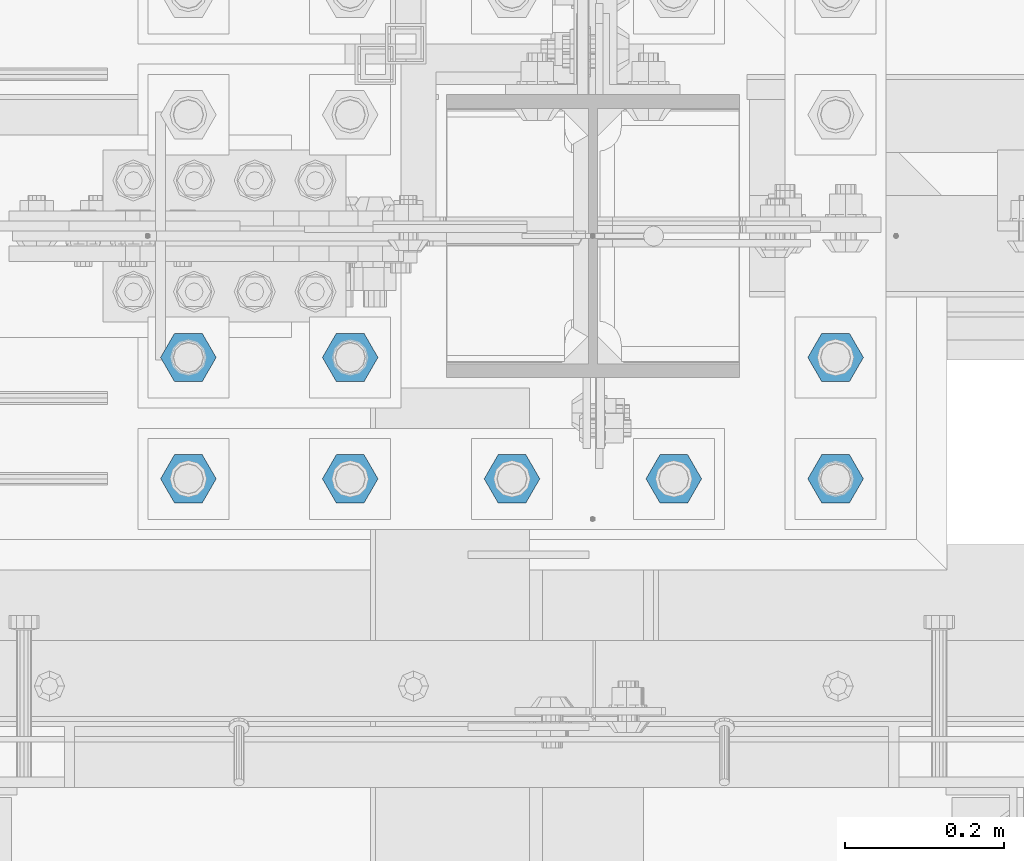
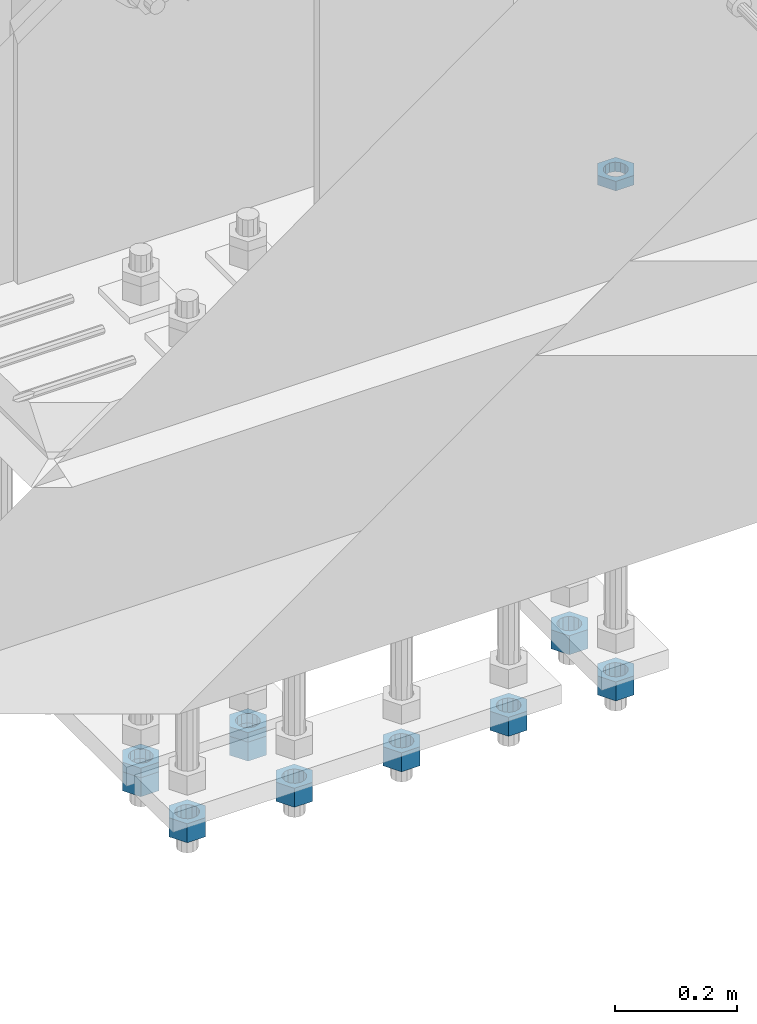
# One storey, part 2815 of 3843: 11 beams, 1 element without a shape of its own.
"""IFC2X3 building model written with IfcOpenShell, lengths in millimetres."""

from ifc_helpers import new_model, si_unit, frame, origin_with_axes, place, context, subcontext, project, spatial, faceted_brep, material, type_object, element, aggregate, save


model = new_model("IFC2X3")

# Units and contexts
model_context = context("Model", 3, precision=1e-05, world=origin_with_axes())
body_context = subcontext(model_context, "Body", "Model", "MODEL_VIEW")
ifc_project = project(units=[si_unit("LENGTHUNIT", "METRE", prefix="MILLI"), si_unit("AREAUNIT", "SQUARE_METRE"), si_unit("VOLUMEUNIT", "CUBIC_METRE"), si_unit("MASSUNIT", "GRAM", prefix="KILO"), si_unit("TIMEUNIT", "SECOND"), si_unit("PLANEANGLEUNIT", "RADIAN"), si_unit("SOLIDANGLEUNIT", "STERADIAN"), si_unit("THERMODYNAMICTEMPERATUREUNIT", "DEGREE_CELSIUS"), si_unit("LUMINOUSINTENSITYUNIT", "LUMEN")], contexts=[model_context])

# Site, building, storey
site_placement = place(None, origin_with_axes())
site = spatial("IfcSite", under=ifc_project, at=site_placement, CompositionType="ELEMENT")
building_placement = place(site_placement, origin_with_axes())
building = spatial("IfcBuilding", under=site, at=building_placement, Name="Undefined", CompositionType="ELEMENT")
storey_placement = place(building_placement, origin_with_axes())
storey = spatial("IfcBuildingStorey", under=building, at=storey_placement, Name="Undefined", CompositionType="ELEMENT", Elevation=0.0)

# Assembly, beams
assembly_placement = place(storey_placement, origin_with_axes())
assembly = element("IfcElementAssembly", 1, at=assembly_placement, inside=storey, Name="TEMPLATE", AssemblyPlace="NOTDEFINED", PredefinedType="RIGID_FRAME")
ifc_material = material(Name="STEEL/A572-50")
beam_type_1 = type_object("IfcBeamType", Name="1-1/2_HEAVY_HEX_NUT", PredefinedType="NOTDEFINED")
beam_1_placement = place(assembly_placement, frame((49301.4, 25311.1, 28746.4500015259), z_axis=(0.0, -1.0, 0.0), x_axis=(0.0, 0.0, -1.0)))
beam_1 = element("IfcBeam", 2, at=beam_1_placement, type_object=beam_type_1, material=ifc_material, Name="NUT", ObjectType="1-1/2_HEAVY_HEX_NUT", context=body_context, shape_type="Brep", body=[
    faceted_brep([(0.0, -34.9199981689453, 0.0), (0.0, -17.4599990844727, -30.25), (38.0999999999985, -17.4599990844727, -30.25), (38.0999999999985, -34.9199981689453, 0.0), (0.0, 17.4599990844727, -30.25), (38.0999999999985, 17.4599990844727, -30.25), (0.0, 34.9199981689453, 0.0), (38.0999999999985, 34.9199981689453, 0.0), (0.0, 17.4599990844727, 30.25), (38.0999999999985, 17.4599990844727, 30.25), (0.0, -17.4599990844727, 30.25), (38.0999999999985, -17.4599990844727, 30.25), (0.0, 0.0, 20.6399993896484), (0.0, 8.9553601105581, 18.5959968835959), (38.0999999999985, 8.9553601105581, 18.5959968835959), (38.0999999999985, 0.0, 20.6399993896484), (0.0, 16.1370013209525, 12.8688291298167), (38.0999999999985, 16.1370013209525, 12.8688291298167), (0.0, 20.1225115123816, 4.59283194104501), (38.0999999999985, 20.1225115123816, 4.59283194104501), (0.0, 20.1225115123816, -4.59283194104501), (38.0999999999985, 20.1225115123816, -4.59283194104501), (0.0, 16.1370013209525, -12.8688291298167), (38.0999999999985, 16.1370013209525, -12.8688291298167), (0.0, 8.9553601105581, -18.5959968835959), (38.0999999999985, 8.9553601105581, -18.5959968835959), (0.0, 0.0, -20.6399993896484), (38.0999999999985, 0.0, -20.6399993896484), (0.0, -8.9553601105581, -18.5959968835959), (38.0999999999985, -8.9553601105581, -18.5959968835959), (0.0, -16.1370013209525, -12.8688291298167), (38.0999999999985, -16.1370013209525, -12.8688291298167), (0.0, -20.1225115123816, -4.59283194104501), (38.0999999999985, -20.1225115123816, -4.59283194104501), (0.0, -20.1225115123816, 4.59283194104501), (38.0999999999985, -20.1225115123816, 4.59283194104501), (0.0, -16.1370013209525, 12.8688291298167), (38.0999999999985, -16.1370013209525, 12.8688291298167), (0.0, -8.9553601105581, 18.5959968835959), (38.0999999999985, -8.9553601105581, 18.5959968835959)], [[[0, 1, 2, 3]], [[1, 4, 5, 2]], [[4, 6, 7, 5]], [[6, 8, 9, 7]], [[8, 10, 11, 9]], [[10, 0, 3, 11]], [[12, 13, 14, 15]], [[13, 16, 17, 14]], [[16, 18, 19, 17]], [[18, 20, 21, 19]], [[20, 22, 23, 21]], [[22, 24, 25, 23]], [[24, 26, 27, 25]], [[26, 28, 29, 27]], [[28, 30, 31, 29]], [[30, 32, 33, 31]], [[32, 34, 35, 33]], [[34, 36, 37, 35]], [[36, 38, 39, 37]], [[38, 12, 15, 39]], [[5, 7, 9, 11, 3, 2], [17, 19, 21, 23, 25, 27, 29, 31, 33, 35, 37, 39, 15, 14]], [[10, 8, 6, 4, 1, 0], [38, 36, 34, 32, 30, 28, 26, 24, 22, 20, 18, 16, 13, 12]]]),
])
beam_2_placement = place(assembly_placement, frame((49098.2, 25311.1, 28746.4500015259), z_axis=(0.0, -1.0, 0.0), x_axis=(0.0, 0.0, -1.0)))
beam_2 = element("IfcBeam", 3, at=beam_2_placement, type_object=beam_type_1, material=ifc_material, Name="NUT", ObjectType="1-1/2_HEAVY_HEX_NUT", context=body_context, shape_type="Brep", body=[
    faceted_brep([(0.0, -34.9199981689453, 0.0), (0.0, -17.4599990844727, -30.25), (38.0999999999985, -17.4599990844727, -30.25), (38.0999999999985, -34.9199981689453, 0.0), (0.0, 17.4599990844727, -30.25), (38.0999999999985, 17.4599990844727, -30.25), (0.0, 34.9199981689453, 0.0), (38.0999999999985, 34.9199981689453, 0.0), (0.0, 17.4599990844727, 30.25), (38.0999999999985, 17.4599990844727, 30.25), (0.0, -17.4599990844727, 30.25), (38.0999999999985, -17.4599990844727, 30.25), (0.0, 0.0, 20.6399993896484), (0.0, 8.9553601105581, 18.5959968835959), (38.0999999999985, 8.9553601105581, 18.5959968835959), (38.0999999999985, 0.0, 20.6399993896484), (0.0, 16.1370013209525, 12.8688291298167), (38.0999999999985, 16.1370013209525, 12.8688291298167), (0.0, 20.1225115123816, 4.59283194104501), (38.0999999999985, 20.1225115123816, 4.59283194104501), (0.0, 20.1225115123816, -4.59283194104501), (38.0999999999985, 20.1225115123816, -4.59283194104501), (0.0, 16.1370013209525, -12.8688291298167), (38.0999999999985, 16.1370013209525, -12.8688291298167), (0.0, 8.9553601105581, -18.5959968835959), (38.0999999999985, 8.9553601105581, -18.5959968835959), (0.0, 0.0, -20.6399993896484), (38.0999999999985, 0.0, -20.6399993896484), (0.0, -8.9553601105581, -18.5959968835959), (38.0999999999985, -8.9553601105581, -18.5959968835959), (0.0, -16.1370013209525, -12.8688291298167), (38.0999999999985, -16.1370013209525, -12.8688291298167), (0.0, -20.1225115123816, -4.59283194104501), (38.0999999999985, -20.1225115123816, -4.59283194104501), (0.0, -20.1225115123816, 4.59283194104501), (38.0999999999985, -20.1225115123816, 4.59283194104501), (0.0, -16.1370013209525, 12.8688291298167), (38.0999999999985, -16.1370013209525, 12.8688291298167), (0.0, -8.9553601105581, 18.5959968835959), (38.0999999999985, -8.9553601105581, 18.5959968835959)], [[[0, 1, 2, 3]], [[1, 4, 5, 2]], [[4, 6, 7, 5]], [[6, 8, 9, 7]], [[8, 10, 11, 9]], [[10, 0, 3, 11]], [[12, 13, 14, 15]], [[13, 16, 17, 14]], [[16, 18, 19, 17]], [[18, 20, 21, 19]], [[20, 22, 23, 21]], [[22, 24, 25, 23]], [[24, 26, 27, 25]], [[26, 28, 29, 27]], [[28, 30, 31, 29]], [[30, 32, 33, 31]], [[32, 34, 35, 33]], [[34, 36, 37, 35]], [[36, 38, 39, 37]], [[38, 12, 15, 39]], [[5, 7, 9, 11, 3, 2], [17, 19, 21, 23, 25, 27, 29, 31, 33, 35, 37, 39, 15, 14]], [[10, 8, 6, 4, 1, 0], [38, 36, 34, 32, 30, 28, 26, 24, 22, 20, 18, 16, 13, 12]]]),
])
beam_3_placement = place(assembly_placement, frame((48895.0, 25311.1, 28746.4500015259), z_axis=(0.0, -1.0, 0.0), x_axis=(0.0, 0.0, -1.0)))
beam_3 = element("IfcBeam", 4, at=beam_3_placement, type_object=beam_type_1, material=ifc_material, Name="NUT", ObjectType="1-1/2_HEAVY_HEX_NUT", context=body_context, shape_type="Brep", body=[
    faceted_brep([(0.0, -34.9199981689453, 0.0), (0.0, -17.4599990844727, -30.25), (38.0999999999985, -17.4599990844727, -30.25), (38.0999999999985, -34.9199981689453, 0.0), (0.0, 17.4599990844727, -30.25), (38.0999999999985, 17.4599990844727, -30.25), (0.0, 34.9199981689453, 0.0), (38.0999999999985, 34.9199981689453, 0.0), (0.0, 17.4599990844727, 30.25), (38.0999999999985, 17.4599990844727, 30.25), (0.0, -17.4599990844727, 30.25), (38.0999999999985, -17.4599990844727, 30.25), (0.0, 0.0, 20.6399993896484), (0.0, 8.9553601105581, 18.5959968835959), (38.0999999999985, 8.9553601105581, 18.5959968835959), (38.0999999999985, 0.0, 20.6399993896484), (0.0, 16.1370013209525, 12.8688291298167), (38.0999999999985, 16.1370013209525, 12.8688291298167), (0.0, 20.1225115123816, 4.59283194104501), (38.0999999999985, 20.1225115123816, 4.59283194104501), (0.0, 20.1225115123816, -4.59283194104501), (38.0999999999985, 20.1225115123816, -4.59283194104501), (0.0, 16.1370013209525, -12.8688291298167), (38.0999999999985, 16.1370013209525, -12.8688291298167), (0.0, 8.9553601105581, -18.5959968835959), (38.0999999999985, 8.9553601105581, -18.5959968835959), (0.0, 0.0, -20.6399993896484), (38.0999999999985, 0.0, -20.6399993896484), (0.0, -8.9553601105581, -18.5959968835959), (38.0999999999985, -8.9553601105581, -18.5959968835959), (0.0, -16.1370013209525, -12.8688291298167), (38.0999999999985, -16.1370013209525, -12.8688291298167), (0.0, -20.1225115123816, -4.59283194104501), (38.0999999999985, -20.1225115123816, -4.59283194104501), (0.0, -20.1225115123816, 4.59283194104501), (38.0999999999985, -20.1225115123816, 4.59283194104501), (0.0, -16.1370013209525, 12.8688291298167), (38.0999999999985, -16.1370013209525, 12.8688291298167), (0.0, -8.9553601105581, 18.5959968835959), (38.0999999999985, -8.9553601105581, 18.5959968835959)], [[[0, 1, 2, 3]], [[1, 4, 5, 2]], [[4, 6, 7, 5]], [[6, 8, 9, 7]], [[8, 10, 11, 9]], [[10, 0, 3, 11]], [[12, 13, 14, 15]], [[13, 16, 17, 14]], [[16, 18, 19, 17]], [[18, 20, 21, 19]], [[20, 22, 23, 21]], [[22, 24, 25, 23]], [[24, 26, 27, 25]], [[26, 28, 29, 27]], [[28, 30, 31, 29]], [[30, 32, 33, 31]], [[32, 34, 35, 33]], [[34, 36, 37, 35]], [[36, 38, 39, 37]], [[38, 12, 15, 39]], [[5, 7, 9, 11, 3, 2], [17, 19, 21, 23, 25, 27, 29, 31, 33, 35, 37, 39, 15, 14]], [[10, 8, 6, 4, 1, 0], [38, 36, 34, 32, 30, 28, 26, 24, 22, 20, 18, 16, 13, 12]]]),
])
beam_4_placement = place(assembly_placement, frame((48691.8, 25311.1, 28746.4500015259), z_axis=(0.0, 1.0, 0.0), x_axis=(0.0, 0.0, -1.0)))
beam_4 = element("IfcBeam", 5, at=beam_4_placement, type_object=beam_type_1, material=ifc_material, Name="NUT", ObjectType="1-1/2_HEAVY_HEX_NUT", context=body_context, shape_type="Brep", body=[
    faceted_brep([(0.0, -34.9199981689453, 0.0), (0.0, -17.4599990844727, -30.25), (38.0999999999985, -17.4599990844727, -30.25), (38.0999999999985, -34.9199981689453, 0.0), (0.0, 17.4599990844727, -30.25), (38.0999999999985, 17.4599990844727, -30.25), (0.0, 34.9199981689453, 0.0), (38.0999999999985, 34.9199981689453, 0.0), (0.0, 17.4599990844727, 30.25), (38.0999999999985, 17.4599990844727, 30.25), (0.0, -17.4599990844727, 30.25), (38.0999999999985, -17.4599990844727, 30.25), (0.0, 0.0, 20.6399993896484), (0.0, 8.9553601105581, 18.5959968835959), (38.0999999999985, 8.9553601105581, 18.5959968835959), (38.0999999999985, 0.0, 20.6399993896484), (0.0, 16.1370013209525, 12.8688291298167), (38.0999999999985, 16.1370013209525, 12.8688291298167), (0.0, 20.1225115123816, 4.59283194104501), (38.0999999999985, 20.1225115123816, 4.59283194104501), (0.0, 20.1225115123816, -4.59283194104501), (38.0999999999985, 20.1225115123816, -4.59283194104501), (0.0, 16.1370013209525, -12.8688291298167), (38.0999999999985, 16.1370013209525, -12.8688291298167), (0.0, 8.9553601105581, -18.5959968835959), (38.0999999999985, 8.9553601105581, -18.5959968835959), (0.0, 0.0, -20.6399993896484), (38.0999999999985, 0.0, -20.6399993896484), (0.0, -8.9553601105581, -18.5959968835959), (38.0999999999985, -8.9553601105581, -18.5959968835959), (0.0, -16.1370013209525, -12.8688291298167), (38.0999999999985, -16.1370013209525, -12.8688291298167), (0.0, -20.1225115123816, -4.59283194104501), (38.0999999999985, -20.1225115123816, -4.59283194104501), (0.0, -20.1225115123816, 4.59283194104501), (38.0999999999985, -20.1225115123816, 4.59283194104501), (0.0, -16.1370013209525, 12.8688291298167), (38.0999999999985, -16.1370013209525, 12.8688291298167), (0.0, -8.9553601105581, 18.5959968835959), (38.0999999999985, -8.9553601105581, 18.5959968835959)], [[[0, 1, 2, 3]], [[1, 4, 5, 2]], [[4, 6, 7, 5]], [[6, 8, 9, 7]], [[8, 10, 11, 9]], [[10, 0, 3, 11]], [[12, 13, 14, 15]], [[13, 16, 17, 14]], [[16, 18, 19, 17]], [[18, 20, 21, 19]], [[20, 22, 23, 21]], [[22, 24, 25, 23]], [[24, 26, 27, 25]], [[26, 28, 29, 27]], [[28, 30, 31, 29]], [[30, 32, 33, 31]], [[32, 34, 35, 33]], [[34, 36, 37, 35]], [[36, 38, 39, 37]], [[38, 12, 15, 39]], [[5, 7, 9, 11, 3, 2], [17, 19, 21, 23, 25, 27, 29, 31, 33, 35, 37, 39, 15, 14]], [[10, 8, 6, 4, 1, 0], [38, 36, 34, 32, 30, 28, 26, 24, 22, 20, 18, 16, 13, 12]]]),
])
beam_5_placement = place(assembly_placement, frame((48488.6, 25311.1, 28746.4500015259), z_axis=(0.0, 1.0, 0.0), x_axis=(0.0, 0.0, -1.0)))
beam_5 = element("IfcBeam", 6, at=beam_5_placement, type_object=beam_type_1, material=ifc_material, Name="NUT", ObjectType="1-1/2_HEAVY_HEX_NUT", context=body_context, shape_type="Brep", body=[
    faceted_brep([(0.0, -34.9199981689453, 0.0), (0.0, -17.4599990844727, -30.25), (38.0999999999985, -17.4599990844727, -30.25), (38.0999999999985, -34.9199981689453, 0.0), (0.0, 17.4599990844727, -30.25), (38.0999999999985, 17.4599990844727, -30.25), (0.0, 34.9199981689453, 0.0), (38.0999999999985, 34.9199981689453, 0.0), (0.0, 17.4599990844727, 30.25), (38.0999999999985, 17.4599990844727, 30.25), (0.0, -17.4599990844727, 30.25), (38.0999999999985, -17.4599990844727, 30.25), (0.0, 0.0, 20.6399993896484), (0.0, 8.9553601105581, 18.5959968835959), (38.0999999999985, 8.9553601105581, 18.5959968835959), (38.0999999999985, 0.0, 20.6399993896484), (0.0, 16.1370013209525, 12.8688291298167), (38.0999999999985, 16.1370013209525, 12.8688291298167), (0.0, 20.1225115123816, 4.59283194104501), (38.0999999999985, 20.1225115123816, 4.59283194104501), (0.0, 20.1225115123816, -4.59283194104501), (38.0999999999985, 20.1225115123816, -4.59283194104501), (0.0, 16.1370013209525, -12.8688291298167), (38.0999999999985, 16.1370013209525, -12.8688291298167), (0.0, 8.9553601105581, -18.5959968835959), (38.0999999999985, 8.9553601105581, -18.5959968835959), (0.0, 0.0, -20.6399993896484), (38.0999999999985, 0.0, -20.6399993896484), (0.0, -8.9553601105581, -18.5959968835959), (38.0999999999985, -8.9553601105581, -18.5959968835959), (0.0, -16.1370013209525, -12.8688291298167), (38.0999999999985, -16.1370013209525, -12.8688291298167), (0.0, -20.1225115123816, -4.59283194104501), (38.0999999999985, -20.1225115123816, -4.59283194104501), (0.0, -20.1225115123816, 4.59283194104501), (38.0999999999985, -20.1225115123816, 4.59283194104501), (0.0, -16.1370013209525, 12.8688291298167), (38.0999999999985, -16.1370013209525, 12.8688291298167), (0.0, -8.9553601105581, 18.5959968835959), (38.0999999999985, -8.9553601105581, 18.5959968835959)], [[[0, 1, 2, 3]], [[1, 4, 5, 2]], [[4, 6, 7, 5]], [[6, 8, 9, 7]], [[8, 10, 11, 9]], [[10, 0, 3, 11]], [[12, 13, 14, 15]], [[13, 16, 17, 14]], [[16, 18, 19, 17]], [[18, 20, 21, 19]], [[20, 22, 23, 21]], [[22, 24, 25, 23]], [[24, 26, 27, 25]], [[26, 28, 29, 27]], [[28, 30, 31, 29]], [[30, 32, 33, 31]], [[32, 34, 35, 33]], [[34, 36, 37, 35]], [[36, 38, 39, 37]], [[38, 12, 15, 39]], [[5, 7, 9, 11, 3, 2], [17, 19, 21, 23, 25, 27, 29, 31, 33, 35, 37, 39, 15, 14]], [[10, 8, 6, 4, 1, 0], [38, 36, 34, 32, 30, 28, 26, 24, 22, 20, 18, 16, 13, 12]]]),
])
beam_6_placement = place(assembly_placement, frame((49301.4, 25463.5, 28746.4500015259), z_axis=(0.0, -1.0, 0.0), x_axis=(0.0, 0.0, -1.0)))
beam_6 = element("IfcBeam", 7, at=beam_6_placement, type_object=beam_type_1, material=ifc_material, Name="NUT", ObjectType="1-1/2_HEAVY_HEX_NUT", context=body_context, shape_type="Brep", body=[
    faceted_brep([(0.0, -34.9199981689453, 0.0), (0.0, -17.4599990844727, -30.25), (38.0999999999985, -17.4599990844727, -30.25), (38.0999999999985, -34.9199981689453, 0.0), (0.0, 17.4599990844727, -30.25), (38.0999999999985, 17.4599990844727, -30.25), (0.0, 34.9199981689453, 0.0), (38.0999999999985, 34.9199981689453, 0.0), (0.0, 17.4599990844727, 30.25), (38.0999999999985, 17.4599990844727, 30.25), (0.0, -17.4599990844727, 30.25), (38.0999999999985, -17.4599990844727, 30.25), (0.0, 0.0, 20.6399993896484), (0.0, 8.9553601105581, 18.5959968835959), (38.0999999999985, 8.9553601105581, 18.5959968835959), (38.0999999999985, 0.0, 20.6399993896484), (0.0, 16.1370013209525, 12.8688291298167), (38.0999999999985, 16.1370013209525, 12.8688291298167), (0.0, 20.1225115123816, 4.59283194104501), (38.0999999999985, 20.1225115123816, 4.59283194104501), (0.0, 20.1225115123816, -4.59283194104501), (38.0999999999985, 20.1225115123816, -4.59283194104501), (0.0, 16.1370013209525, -12.8688291298167), (38.0999999999985, 16.1370013209525, -12.8688291298167), (0.0, 8.9553601105581, -18.5959968835959), (38.0999999999985, 8.9553601105581, -18.5959968835959), (0.0, 0.0, -20.6399993896484), (38.0999999999985, 0.0, -20.6399993896484), (0.0, -8.9553601105581, -18.5959968835959), (38.0999999999985, -8.9553601105581, -18.5959968835959), (0.0, -16.1370013209525, -12.8688291298167), (38.0999999999985, -16.1370013209525, -12.8688291298167), (0.0, -20.1225115123816, -4.59283194104501), (38.0999999999985, -20.1225115123816, -4.59283194104501), (0.0, -20.1225115123816, 4.59283194104501), (38.0999999999985, -20.1225115123816, 4.59283194104501), (0.0, -16.1370013209525, 12.8688291298167), (38.0999999999985, -16.1370013209525, 12.8688291298167), (0.0, -8.9553601105581, 18.5959968835959), (38.0999999999985, -8.9553601105581, 18.5959968835959)], [[[0, 1, 2, 3]], [[1, 4, 5, 2]], [[4, 6, 7, 5]], [[6, 8, 9, 7]], [[8, 10, 11, 9]], [[10, 0, 3, 11]], [[12, 13, 14, 15]], [[13, 16, 17, 14]], [[16, 18, 19, 17]], [[18, 20, 21, 19]], [[20, 22, 23, 21]], [[22, 24, 25, 23]], [[24, 26, 27, 25]], [[26, 28, 29, 27]], [[28, 30, 31, 29]], [[30, 32, 33, 31]], [[32, 34, 35, 33]], [[34, 36, 37, 35]], [[36, 38, 39, 37]], [[38, 12, 15, 39]], [[5, 7, 9, 11, 3, 2], [17, 19, 21, 23, 25, 27, 29, 31, 33, 35, 37, 39, 15, 14]], [[10, 8, 6, 4, 1, 0], [38, 36, 34, 32, 30, 28, 26, 24, 22, 20, 18, 16, 13, 12]]]),
])
beam_7_placement = place(assembly_placement, frame((48691.8, 25463.5, 28746.4500015259), z_axis=(0.0, 1.0, 0.0), x_axis=(0.0, 0.0, -1.0)))
beam_7 = element("IfcBeam", 8, at=beam_7_placement, type_object=beam_type_1, material=ifc_material, Name="NUT", ObjectType="1-1/2_HEAVY_HEX_NUT", context=body_context, shape_type="Brep", body=[
    faceted_brep([(0.0, -34.9199981689453, 0.0), (0.0, -17.4599990844727, -30.25), (38.0999999999985, -17.4599990844727, -30.25), (38.0999999999985, -34.9199981689453, 0.0), (0.0, 17.4599990844727, -30.25), (38.0999999999985, 17.4599990844727, -30.25), (0.0, 34.9199981689453, 0.0), (38.0999999999985, 34.9199981689453, 0.0), (0.0, 17.4599990844727, 30.25), (38.0999999999985, 17.4599990844727, 30.25), (0.0, -17.4599990844727, 30.25), (38.0999999999985, -17.4599990844727, 30.25), (0.0, 0.0, 20.6399993896484), (0.0, 8.9553601105581, 18.5959968835959), (38.0999999999985, 8.9553601105581, 18.5959968835959), (38.0999999999985, 0.0, 20.6399993896484), (0.0, 16.1370013209525, 12.8688291298167), (38.0999999999985, 16.1370013209525, 12.8688291298167), (0.0, 20.1225115123816, 4.59283194104501), (38.0999999999985, 20.1225115123816, 4.59283194104501), (0.0, 20.1225115123816, -4.59283194104501), (38.0999999999985, 20.1225115123816, -4.59283194104501), (0.0, 16.1370013209525, -12.8688291298167), (38.0999999999985, 16.1370013209525, -12.8688291298167), (0.0, 8.9553601105581, -18.5959968835959), (38.0999999999985, 8.9553601105581, -18.5959968835959), (0.0, 0.0, -20.6399993896484), (38.0999999999985, 0.0, -20.6399993896484), (0.0, -8.9553601105581, -18.5959968835959), (38.0999999999985, -8.9553601105581, -18.5959968835959), (0.0, -16.1370013209525, -12.8688291298167), (38.0999999999985, -16.1370013209525, -12.8688291298167), (0.0, -20.1225115123816, -4.59283194104501), (38.0999999999985, -20.1225115123816, -4.59283194104501), (0.0, -20.1225115123816, 4.59283194104501), (38.0999999999985, -20.1225115123816, 4.59283194104501), (0.0, -16.1370013209525, 12.8688291298167), (38.0999999999985, -16.1370013209525, 12.8688291298167), (0.0, -8.9553601105581, 18.5959968835959), (38.0999999999985, -8.9553601105581, 18.5959968835959)], [[[0, 1, 2, 3]], [[1, 4, 5, 2]], [[4, 6, 7, 5]], [[6, 8, 9, 7]], [[8, 10, 11, 9]], [[10, 0, 3, 11]], [[12, 13, 14, 15]], [[13, 16, 17, 14]], [[16, 18, 19, 17]], [[18, 20, 21, 19]], [[20, 22, 23, 21]], [[22, 24, 25, 23]], [[24, 26, 27, 25]], [[26, 28, 29, 27]], [[28, 30, 31, 29]], [[30, 32, 33, 31]], [[32, 34, 35, 33]], [[34, 36, 37, 35]], [[36, 38, 39, 37]], [[38, 12, 15, 39]], [[5, 7, 9, 11, 3, 2], [17, 19, 21, 23, 25, 27, 29, 31, 33, 35, 37, 39, 15, 14]], [[10, 8, 6, 4, 1, 0], [38, 36, 34, 32, 30, 28, 26, 24, 22, 20, 18, 16, 13, 12]]]),
])
beam_8_placement = place(assembly_placement, frame((48488.6, 25463.5, 28746.4500015259), z_axis=(0.0, 1.0, 0.0), x_axis=(0.0, 0.0, -1.0)))
beam_8 = element("IfcBeam", 9, at=beam_8_placement, type_object=beam_type_1, material=ifc_material, Name="NUT", ObjectType="1-1/2_HEAVY_HEX_NUT", context=body_context, shape_type="Brep", body=[
    faceted_brep([(0.0, -34.9199981689453, 0.0), (0.0, -17.4599990844727, -30.25), (38.0999999999985, -17.4599990844727, -30.25), (38.0999999999985, -34.9199981689453, 0.0), (0.0, 17.4599990844727, -30.25), (38.0999999999985, 17.4599990844727, -30.25), (0.0, 34.9199981689453, 0.0), (38.0999999999985, 34.9199981689453, 0.0), (0.0, 17.4599990844727, 30.25), (38.0999999999985, 17.4599990844727, 30.25), (0.0, -17.4599990844727, 30.25), (38.0999999999985, -17.4599990844727, 30.25), (0.0, 0.0, 20.6399993896484), (0.0, 8.9553601105581, 18.5959968835959), (38.0999999999985, 8.9553601105581, 18.5959968835959), (38.0999999999985, 0.0, 20.6399993896484), (0.0, 16.1370013209525, 12.8688291298167), (38.0999999999985, 16.1370013209525, 12.8688291298167), (0.0, 20.1225115123816, 4.59283194104501), (38.0999999999985, 20.1225115123816, 4.59283194104501), (0.0, 20.1225115123816, -4.59283194104501), (38.0999999999985, 20.1225115123816, -4.59283194104501), (0.0, 16.1370013209525, -12.8688291298167), (38.0999999999985, 16.1370013209525, -12.8688291298167), (0.0, 8.9553601105581, -18.5959968835959), (38.0999999999985, 8.9553601105581, -18.5959968835959), (0.0, 0.0, -20.6399993896484), (38.0999999999985, 0.0, -20.6399993896484), (0.0, -8.9553601105581, -18.5959968835959), (38.0999999999985, -8.9553601105581, -18.5959968835959), (0.0, -16.1370013209525, -12.8688291298167), (38.0999999999985, -16.1370013209525, -12.8688291298167), (0.0, -20.1225115123816, -4.59283194104501), (38.0999999999985, -20.1225115123816, -4.59283194104501), (0.0, -20.1225115123816, 4.59283194104501), (38.0999999999985, -20.1225115123816, 4.59283194104501), (0.0, -16.1370013209525, 12.8688291298167), (38.0999999999985, -16.1370013209525, 12.8688291298167), (0.0, -8.9553601105581, 18.5959968835959), (38.0999999999985, -8.9553601105581, 18.5959968835959)], [[[0, 1, 2, 3]], [[1, 4, 5, 2]], [[4, 6, 7, 5]], [[6, 8, 9, 7]], [[8, 10, 11, 9]], [[10, 0, 3, 11]], [[12, 13, 14, 15]], [[13, 16, 17, 14]], [[16, 18, 19, 17]], [[18, 20, 21, 19]], [[20, 22, 23, 21]], [[22, 24, 25, 23]], [[24, 26, 27, 25]], [[26, 28, 29, 27]], [[28, 30, 31, 29]], [[30, 32, 33, 31]], [[32, 34, 35, 33]], [[34, 36, 37, 35]], [[36, 38, 39, 37]], [[38, 12, 15, 39]], [[5, 7, 9, 11, 3, 2], [17, 19, 21, 23, 25, 27, 29, 31, 33, 35, 37, 39, 15, 14]], [[10, 8, 6, 4, 1, 0], [38, 36, 34, 32, 30, 28, 26, 24, 22, 20, 18, 16, 13, 12]]]),
])
beam_type_2 = type_object("IfcBeamType", Name="1-1/2_HALF_NUT", PredefinedType="NOTDEFINED")
beam_9_placement = place(assembly_placement, frame((48691.8, 25463.5, 28765.5), z_axis=(0.0, 1.0, 0.0), x_axis=(0.0, 0.0, -1.0)))
beam_9 = element("IfcBeam", 10, at=beam_9_placement, type_object=beam_type_2, material=ifc_material, Name="NUT", ObjectType="1-1/2_HALF_NUT", context=body_context, shape_type="Brep", body=[
    faceted_brep([(0.0, -34.9199981689453, 0.0), (0.0, -17.4599990844727, -30.25), (19.0500000000029, -17.4599990844727, -30.25), (19.0500000000029, -34.9199981689453, 0.0), (0.0, 17.4599990844727, -30.25), (19.0500000000029, 17.4599990844727, -30.25), (0.0, 34.9199981689453, 0.0), (19.0500000000029, 34.9199981689453, 0.0), (0.0, 17.4599990844727, 30.25), (19.0500000000029, 17.4599990844727, 30.25), (0.0, -17.4599990844727, 30.25), (19.0500000000029, -17.4599990844727, 30.25), (0.0, 0.0, 20.6399993896484), (0.0, 8.9553601105581, 18.5959968835959), (19.0500000000029, 8.95536011056538, 18.5959968835959), (19.0500000000029, 0.0, 20.6399993896484), (0.0, 16.1370013209525, 12.8688291298167), (19.0500000000029, 16.1370013209489, 12.8688291298167), (0.0, 20.1225115123816, 4.59283194104501), (19.0500000000029, 20.1225115123852, 4.59283194104501), (0.0, 20.1225115123816, -4.59283194104501), (19.0500000000029, 20.1225115123852, -4.59283194104501), (0.0, 16.1370013209525, -12.8688291298167), (19.0500000000029, 16.1370013209489, -12.8688291298167), (0.0, 8.9553601105581, -18.5959968835959), (19.0500000000029, 8.95536011056538, -18.5959968835959), (0.0, 0.0, -20.6399993896484), (19.0500000000029, 0.0, -20.6399993896484), (0.0, -8.9553601105581, -18.5959968835959), (19.0500000000029, -8.95536011056538, -18.5959968835959), (0.0, -16.1370013209525, -12.8688291298167), (19.0500000000029, -16.1370013209489, -12.8688291298167), (0.0, -20.1225115123816, -4.59283194104501), (19.0500000000029, -20.1225115123852, -4.59283194104501), (0.0, -20.1225115123816, 4.59283194104501), (19.0500000000029, -20.1225115123852, 4.59283194104501), (0.0, -16.1370013209525, 12.8688291298167), (19.0500000000029, -16.1370013209489, 12.8688291298167), (0.0, -8.9553601105581, 18.5959968835959), (19.0500000000029, -8.95536011056538, 18.5959968835959)], [[[0, 1, 2, 3]], [[1, 4, 5, 2]], [[4, 6, 7, 5]], [[6, 8, 9, 7]], [[8, 10, 11, 9]], [[10, 0, 3, 11]], [[12, 13, 14, 15]], [[13, 16, 17, 14]], [[16, 18, 19, 17]], [[18, 20, 21, 19]], [[20, 22, 23, 21]], [[22, 24, 25, 23]], [[24, 26, 27, 25]], [[26, 28, 29, 27]], [[28, 30, 31, 29]], [[30, 32, 33, 31]], [[32, 34, 35, 33]], [[34, 36, 37, 35]], [[36, 38, 39, 37]], [[38, 12, 15, 39]], [[5, 7, 9, 11, 3, 2], [17, 19, 21, 23, 25, 27, 29, 31, 33, 35, 37, 39, 15, 14]], [[10, 8, 6, 4, 1, 0], [38, 36, 34, 32, 30, 28, 26, 24, 22, 20, 18, 16, 13, 12]]]),
])
beam_10_placement = place(assembly_placement, frame((48488.6, 25463.5, 28765.5), z_axis=(0.0, 1.0, 0.0), x_axis=(0.0, 0.0, -1.0)))
beam_10 = element("IfcBeam", 11, at=beam_10_placement, type_object=beam_type_2, material=ifc_material, Name="NUT", ObjectType="1-1/2_HALF_NUT", context=body_context, shape_type="Brep", body=[
    faceted_brep([(0.0, -34.9199981689453, 0.0), (0.0, -17.4599990844727, -30.25), (19.0500000000029, -17.4599990844727, -30.25), (19.0500000000029, -34.9199981689453, 0.0), (0.0, 17.4599990844727, -30.25), (19.0500000000029, 17.4599990844727, -30.25), (0.0, 34.9199981689453, 0.0), (19.0500000000029, 34.9199981689453, 0.0), (0.0, 17.4599990844727, 30.25), (19.0500000000029, 17.4599990844727, 30.25), (0.0, -17.4599990844727, 30.25), (19.0500000000029, -17.4599990844727, 30.25), (0.0, 0.0, 20.6399993896484), (0.0, 8.9553601105581, 18.5959968835959), (19.0500000000029, 8.95536011056538, 18.5959968835959), (19.0500000000029, 0.0, 20.6399993896484), (0.0, 16.1370013209525, 12.8688291298167), (19.0500000000029, 16.1370013209489, 12.8688291298167), (0.0, 20.1225115123816, 4.59283194104501), (19.0500000000029, 20.1225115123852, 4.59283194104501), (0.0, 20.1225115123816, -4.59283194104501), (19.0500000000029, 20.1225115123852, -4.59283194104501), (0.0, 16.1370013209525, -12.8688291298167), (19.0500000000029, 16.1370013209489, -12.8688291298167), (0.0, 8.9553601105581, -18.5959968835959), (19.0500000000029, 8.95536011056538, -18.5959968835959), (0.0, 0.0, -20.6399993896484), (19.0500000000029, 0.0, -20.6399993896484), (0.0, -8.9553601105581, -18.5959968835959), (19.0500000000029, -8.95536011056538, -18.5959968835959), (0.0, -16.1370013209525, -12.8688291298167), (19.0500000000029, -16.1370013209489, -12.8688291298167), (0.0, -20.1225115123816, -4.59283194104501), (19.0500000000029, -20.1225115123852, -4.59283194104501), (0.0, -20.1225115123816, 4.59283194104501), (19.0500000000029, -20.1225115123852, 4.59283194104501), (0.0, -16.1370013209525, 12.8688291298167), (19.0500000000029, -16.1370013209489, 12.8688291298167), (0.0, -8.9553601105581, 18.5959968835959), (19.0500000000029, -8.95536011056538, 18.5959968835959)], [[[0, 1, 2, 3]], [[1, 4, 5, 2]], [[4, 6, 7, 5]], [[6, 8, 9, 7]], [[8, 10, 11, 9]], [[10, 0, 3, 11]], [[12, 13, 14, 15]], [[13, 16, 17, 14]], [[16, 18, 19, 17]], [[18, 20, 21, 19]], [[20, 22, 23, 21]], [[22, 24, 25, 23]], [[24, 26, 27, 25]], [[26, 28, 29, 27]], [[28, 30, 31, 29]], [[30, 32, 33, 31]], [[32, 34, 35, 33]], [[34, 36, 37, 35]], [[36, 38, 39, 37]], [[38, 12, 15, 39]], [[5, 7, 9, 11, 3, 2], [17, 19, 21, 23, 25, 27, 29, 31, 33, 35, 37, 39, 15, 14]], [[10, 8, 6, 4, 1, 0], [38, 36, 34, 32, 30, 28, 26, 24, 22, 20, 18, 16, 13, 12]]]),
])
beam_11_placement = place(assembly_placement, frame((49301.4, 25311.1, 29749.75), z_axis=(0.0, -1.0, 0.0), x_axis=(0.0, 0.0, -1.0)))
beam_11 = element("IfcBeam", 12, at=beam_11_placement, type_object=beam_type_2, material=ifc_material, Name="NUT", ObjectType="1-1/2_HALF_NUT", context=body_context, shape_type="Brep", body=[
    faceted_brep([(0.0, -34.9199981689453, 0.0), (0.0, -17.4599990844727, -30.25), (19.0500000000029, -17.4599990844727, -30.25), (19.0500000000029, -34.9199981689453, 0.0), (0.0, 17.4599990844727, -30.25), (19.0500000000029, 17.4599990844727, -30.25), (0.0, 34.9199981689453, 0.0), (19.0500000000029, 34.9199981689453, 0.0), (0.0, 17.4599990844727, 30.25), (19.0500000000029, 17.4599990844727, 30.25), (0.0, -17.4599990844727, 30.25), (19.0500000000029, -17.4599990844727, 30.25), (0.0, 0.0, 20.6399993896484), (0.0, 8.9553601105581, 18.5959968835959), (19.0500000000029, 8.95536011056538, 18.5959968835959), (19.0500000000029, 0.0, 20.6399993896484), (0.0, 16.1370013209525, 12.8688291298167), (19.0500000000029, 16.1370013209489, 12.8688291298167), (0.0, 20.1225115123816, 4.59283194104501), (19.0500000000029, 20.1225115123852, 4.59283194104501), (0.0, 20.1225115123816, -4.59283194104501), (19.0500000000029, 20.1225115123852, -4.59283194104501), (0.0, 16.1370013209525, -12.8688291298167), (19.0500000000029, 16.1370013209489, -12.8688291298167), (0.0, 8.9553601105581, -18.5959968835959), (19.0500000000029, 8.95536011056538, -18.5959968835959), (0.0, 0.0, -20.6399993896484), (19.0500000000029, 0.0, -20.6399993896484), (0.0, -8.9553601105581, -18.5959968835959), (19.0500000000029, -8.95536011056538, -18.5959968835959), (0.0, -16.1370013209525, -12.8688291298167), (19.0500000000029, -16.1370013209489, -12.8688291298167), (0.0, -20.1225115123816, -4.59283194104501), (19.0500000000029, -20.1225115123852, -4.59283194104501), (0.0, -20.1225115123816, 4.59283194104501), (19.0500000000029, -20.1225115123852, 4.59283194104501), (0.0, -16.1370013209525, 12.8688291298167), (19.0500000000029, -16.1370013209489, 12.8688291298167), (0.0, -8.9553601105581, 18.5959968835959), (19.0500000000029, -8.95536011056538, 18.5959968835959)], [[[0, 1, 2, 3]], [[1, 4, 5, 2]], [[4, 6, 7, 5]], [[6, 8, 9, 7]], [[8, 10, 11, 9]], [[10, 0, 3, 11]], [[12, 13, 14, 15]], [[13, 16, 17, 14]], [[16, 18, 19, 17]], [[18, 20, 21, 19]], [[20, 22, 23, 21]], [[22, 24, 25, 23]], [[24, 26, 27, 25]], [[26, 28, 29, 27]], [[28, 30, 31, 29]], [[30, 32, 33, 31]], [[32, 34, 35, 33]], [[34, 36, 37, 35]], [[36, 38, 39, 37]], [[38, 12, 15, 39]], [[5, 7, 9, 11, 3, 2], [17, 19, 21, 23, 25, 27, 29, 31, 33, 35, 37, 39, 15, 14]], [[10, 8, 6, 4, 1, 0], [38, 36, 34, 32, 30, 28, 26, 24, 22, 20, 18, 16, 13, 12]]]),
])
aggregate(assembly, [beam_9, beam_10, beam_1, beam_2, beam_3, beam_4, beam_5, beam_6, beam_7, beam_8, beam_11])

save(model, "model.ifc")
